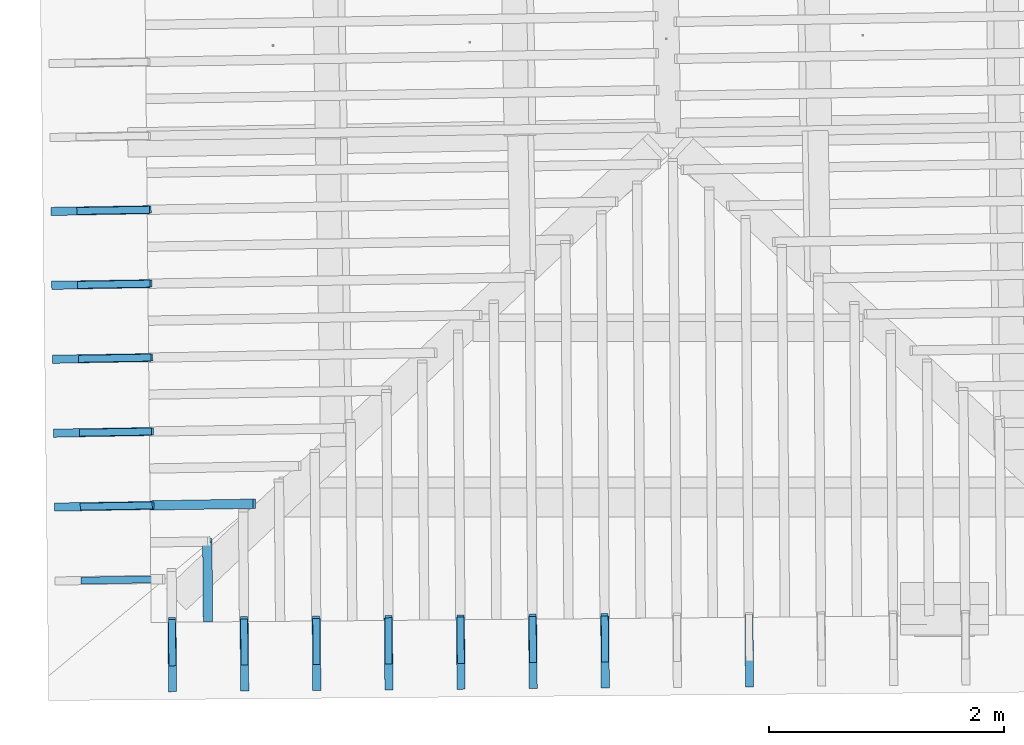
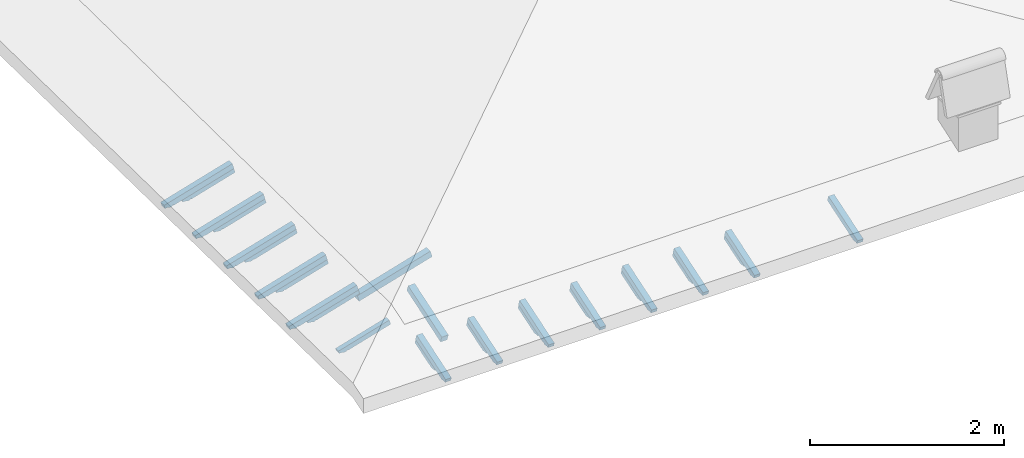
# One storey, part 9 of 19: 28 beams, 6 elements without a shape of their own.
"""IFC4 building model written with IfcOpenShell, lengths in metres."""

from ifc_helpers import new_model, entity, si_unit, converted_unit, derived_unit, direction, frame, origin, place, context, subcontext, project, spatial, line, arc, indexed_curve, outline, extrude, source, transform, mapped, material, type_object, type_shapes, element, aggregate, save


model = new_model("IFC4")

# Units and contexts
model_context = context("Model", 3, precision=1e-05, world=origin(), true_north=direction((6.123233995736766e-17, 1.0)))
body_context = subcontext(model_context, "Body", "Model", "MODEL_VIEW")
ifc_project = project(units=[si_unit("LENGTHUNIT", "METRE"), si_unit("AREAUNIT", "SQUARE_METRE"), si_unit("VOLUMEUNIT", "CUBIC_METRE"), converted_unit("PLANEANGLEUNIT", "DEGREE", entity("IfcPlaneAngleMeasure", 0.017453292519943278), si_unit("PLANEANGLEUNIT", "RADIAN"), dimensions=[0, 0, 0, 0, 0, 0, 0]), derived_unit("THERMALTRANSMITTANCEUNIT", [(si_unit("MASSUNIT", "GRAM", prefix="KILO"), 1), (si_unit("THERMODYNAMICTEMPERATUREUNIT", "KELVIN"), -1), (si_unit("TIMEUNIT", "SECOND"), -3)])], contexts=[model_context])

# Site, building, storey
site_placement = place(None, origin())
site = spatial("IfcSite", under=ifc_project, at=site_placement, CompositionType="ELEMENT")
building_placement = place(site_placement, origin())
building = spatial("IfcBuilding", under=site, at=building_placement, CompositionType="ELEMENT")
storey_placement = place(building_placement, frame((0.0, 0.0, 3.28)))
storey = spatial("IfcBuildingStorey", under=building, at=storey_placement, Name="Livello Copertura", CompositionType="ELEMENT", Elevation=3.28)

# Assembly, beam
assembly_1_placement = place(storey_placement, origin())
assembly_1 = element("IfcElementAssembly", 1, at=assembly_1_placement, inside=storey, Name="Sistema di travi strutturali:Sistema di travi strutturali", ObjectType="Sistema di travi strutturali:Sistema di travi strutturali", AssemblyPlace="NOTDEFINED", PredefinedType="BEAM_GRID")
ifc_material = material(Name="Legno - Legno da costruzione", Category="Legno")
beam_type_1 = type_object("IfcBeamType", Name="Legno:80x80", PredefinedType="JOIST", material=ifc_material)
shared_shape_1 = source(origin(), body_context, "Body", "SweptSolid", [
    extrude(outline(indexed_curve([(-0.4555, -0.04000000000000169), (0.4555, -0.04000000000000169), (0.4555, 0.04000000000000169), (-0.4555, 0.04000000000000169), (-0.4555, -0.04000000000000169)], self_intersect=False)), frame((0.0, 0.0, -0.040000000000005476), z_axis=(0.0, 0.0, 1.0), x_axis=(-1.0, 0.0, 0.0)), (0.0, 0.0, 1.0), 0.07999999999999997),
])
type_shapes(beam_type_1, [shared_shape_1])
beam_1_placement = place(assembly_1_placement, frame((-4.073064353074369, -2.2164447083472925, 0.20185039482082812), z_axis=(-0.2688805697492536, -0.0045944674406682776, 0.9631625667976582), x_axis=(0.9630219859926786, 0.01645553326302694, 0.26891982061526554)))
beam_1 = element("IfcBeam", 2, at=beam_1_placement, type_object=beam_type_1, material=ifc_material, Name="Legno:80x80", ObjectType="Legno:80x80", PredefinedType="JOIST", context=body_context, shape_type="MappedRepresentation", body=[
    mapped(shared_shape_1, transform((0.0, 0.0, 0.0), scale=1.0)),
])
aggregate(assembly_1, [beam_1])

assembly_2_placement = place(storey_placement, origin())
assembly_2 = element("IfcElementAssembly", 3, at=assembly_2_placement, inside=storey, Name="Sistema di travi strutturali:Sistema di travi strutturali", ObjectType="Sistema di travi strutturali:Sistema di travi strutturali", AssemblyPlace="NOTDEFINED", PredefinedType="BEAM_GRID")
beam_type_2 = type_object("IfcBeamType", Name="Legno:80x80", PredefinedType="JOIST", material=ifc_material)
shared_shape_2 = source(origin(), body_context, "Body", "SweptSolid", [
    extrude(outline(indexed_curve([(-0.3615, -0.04000000000000169), (0.3615, -0.04000000000000169), (0.3615, 0.04000000000000169), (-0.3615, 0.04000000000000169), (-0.3615, -0.04000000000000169)], self_intersect=False)), frame((0.0, 0.0, -0.040000000000005476), z_axis=(0.0, 0.0, 1.0), x_axis=(-1.0, 0.0, 0.0)), (0.0, 0.0, 1.0), 0.07999999999999997),
])
type_shapes(beam_type_2, [shared_shape_2])
beam_2_placement = place(assembly_2_placement, frame((-4.0317916790982125, -2.862327603977244, 0.09713162850545398), z_axis=(0.0033933227624359883, -0.32555047006150856, 0.9455185755993167), x_axis=(-0.007932350194779855, 0.9454855083215804, 0.3255675527049189)))
beam_2 = element("IfcBeam", 4, at=beam_2_placement, type_object=beam_type_2, material=ifc_material, Name="Legno:80x80", ObjectType="Legno:80x80", PredefinedType="JOIST", context=body_context, shape_type="MappedRepresentation", body=[
    mapped(shared_shape_2, transform((0.0, 0.0, 0.0), scale=1.0)),
])
aggregate(assembly_2, [beam_2])

# Assembly, beams
assembly_3_placement = place(storey_placement, origin())
assembly_3 = element("IfcElementAssembly", 5, at=assembly_3_placement, inside=storey, Name="Sistema di travi strutturali:Sistema di travi strutturali", ObjectType="Sistema di travi strutturali:Sistema di travi strutturali", AssemblyPlace="NOTDEFINED", PredefinedType="BEAM_GRID")
beam_type_3 = type_object("IfcBeamType", Name="70x70:70x70", PredefinedType="JOIST", material=ifc_material)
shared_shape_3 = source(origin(), body_context, "Body", "SweptSolid", [
    extrude(outline(indexed_curve([(-0.043571428571431446, -0.5697142857142851), (0.02642857142856851, -0.5697142857142851), (0.02642857142856851, 0.17828571428571474), (0.012428571428584384, 0.17828571428571122), (0.026181867029378903, 0.20199531881361585), (0.01842857142857067, 0.22828571428571487), (0.006014118110847633, 0.2512812898006978), (0.0034285714285708425, 0.2772857142857147), (-0.043571428571431446, 0.2772857142857147)], segments=[line(1, 2, 3, 4), arc(4, 5, 6), arc(6, 7, 8), line(8, 9, 1)], self_intersect=False)), frame((-0.1112142857142851, -0.03500000000000078, -0.00857142857143322), z_axis=(0.0, 1.0, 0.0), x_axis=(0.0, 0.0, -1.0)), (0.0, 0.0, 1.0), 0.06999999999999999),
])
type_shapes(beam_type_3, [shared_shape_3])
beam_3_placement = place(assembly_3_placement, frame((-4.954810229137485, -2.23151144493706, 0.09269859893071386), z_axis=(-0.2688805697492528, -0.004594467440668774, 0.9631625667976585), x_axis=(0.9630219859926787, 0.016455533263033215, 0.2689198206152647)))
beam_3 = element("IfcBeam", 6, at=beam_3_placement, type_object=beam_type_3, material=ifc_material, Name="70x70:70x70", ObjectType="70x70:70x70", PredefinedType="JOIST", context=body_context, shape_type="MappedRepresentation", body=[
    mapped(shared_shape_3, transform((0.0, 0.0, 0.0), scale=1.0)),
])
beam_type_4 = type_object("IfcBeamType", Name="70x70:70x70", PredefinedType="JOIST", material=ifc_material)
shared_shape_4 = source(origin(), body_context, "Body", "SweptSolid", [
    extrude(outline(indexed_curve([(-0.04357142857143148, -0.5704285714285708), (0.02642857142856849, -0.5704285714285708), (0.02642857142856849, 0.17857142857142902), (0.01242857142858438, 0.17857142857142563), (0.0261818670293789, 0.20228103309933027), (0.018428571428570715, 0.22857142857142917), (0.006014118110847679, 0.2515670040864121), (0.00342857142857088, 0.27757142857142897), (-0.04357142857143148, 0.27757142857142897)], segments=[line(1, 2, 3, 4), arc(4, 5, 6), arc(6, 7, 8), line(8, 9, 1)], self_intersect=False)), frame((-0.11142857142857084, -0.03500000000000078, -0.008571428571433224), z_axis=(0.0, 1.0, 0.0), x_axis=(0.0, 0.0, -1.0)), (0.0, 0.0, 1.0), 0.06999999999999999),
])
type_shapes(beam_type_4, [shared_shape_4])
beam_4_placement = place(assembly_3_placement, frame((-4.9615916042821295, -1.6015353542947481, 0.09381058631602324), z_axis=(-0.26888056974925356, -0.004594467440668793, 0.9631625667976582), x_axis=(0.9630219859926785, 0.01645553326303299, 0.26891982061526554)))
beam_4 = element("IfcBeam", 7, at=beam_4_placement, type_object=beam_type_4, material=ifc_material, Name="70x70:70x70", ObjectType="70x70:70x70", PredefinedType="JOIST", context=body_context, shape_type="MappedRepresentation", body=[
    mapped(shared_shape_4, transform((0.0, 0.0, 0.0), scale=1.0)),
])
beam_type_5 = type_object("IfcBeamType", Name="70x70:70x70", PredefinedType="JOIST", material=ifc_material)
shared_shape_5 = source(origin(), body_context, "Body", "SweptSolid", [
    extrude(outline(indexed_curve([(-0.043571428571431495, -0.5718571428571425), (0.026428571428568505, -0.5718571428571425), (0.026428571428568505, 0.17914285714285763), (0.012428571428584407, 0.17914285714285424), (0.026181867029378924, 0.20285246167075888), (0.018428571428570704, 0.2291428571428578), (0.006014118110847667, 0.2521384326578407), (0.0034285714285708724, 0.2781428571428576), (-0.043571428571431495, 0.2781428571428576)], segments=[line(1, 2, 3, 4), arc(4, 5, 6), arc(6, 7, 8), line(8, 9, 1)], self_intersect=False)), frame((-0.11185714285714239, -0.03500000000000078, -0.00857142857143322), z_axis=(0.0, 1.0, 0.0), x_axis=(0.0, 0.0, -1.0)), (0.0, 0.0, 1.0), 0.06999999999999999),
])
type_shapes(beam_type_5, [shared_shape_5])
beam_5_placement = place(assembly_3_placement, frame((-4.968372979426771, -0.9715592636524365, 0.09492257370133195), z_axis=(-0.26888056974925356, -0.004594467440668792, 0.9631625667976582), x_axis=(0.9630219859926785, 0.01645553326303318, 0.26891982061526554)))
beam_5 = element("IfcBeam", 8, at=beam_5_placement, type_object=beam_type_5, material=ifc_material, Name="70x70:70x70", ObjectType="70x70:70x70", PredefinedType="JOIST", context=body_context, shape_type="MappedRepresentation", body=[
    mapped(shared_shape_5, transform((0.0, 0.0, 0.0), scale=1.0)),
])
beam_type_6 = type_object("IfcBeamType", Name="70x70:70x70", PredefinedType="JOIST", material=ifc_material)
shared_shape_6 = source(origin(), body_context, "Body", "SweptSolid", [
    extrude(outline(indexed_curve([(-0.043571428571431474, -0.5725714285714281), (0.026428571428568505, -0.5725714285714281), (0.026428571428568505, 0.17942857142857194), (0.012428571428584384, 0.17942857142856855), (0.026181867029378903, 0.20313817595647318), (0.01842857142857069, 0.22942857142857206), (0.0060141181108476546, 0.252424146943555), (0.0034285714285708555, 0.2784285714285719), (-0.043571428571431474, 0.2784285714285719)], segments=[line(1, 2, 3, 4), arc(4, 5, 6), arc(6, 7, 8), line(8, 9, 1)], self_intersect=False)), frame((-0.11207142857142802, -0.03500000000000078, -0.008571428571433214), z_axis=(0.0, 1.0, 0.0), x_axis=(0.0, 0.0, -1.0)), (0.0, 0.0, 1.0), 0.06999999999999999),
])
type_shapes(beam_type_6, [shared_shape_6])
beam_6_placement = place(assembly_3_placement, frame((-4.975154354571416, -0.34158317301012453, 0.09603456108664044), z_axis=(-0.2688805697492534, -0.004594467440668787, 0.9631625667976583), x_axis=(0.9630219859926785, 0.01645553326303317, 0.2689198206152653)))
beam_6 = element("IfcBeam", 9, at=beam_6_placement, type_object=beam_type_6, material=ifc_material, Name="70x70:70x70", ObjectType="70x70:70x70", PredefinedType="JOIST", context=body_context, shape_type="MappedRepresentation", body=[
    mapped(shared_shape_6, transform((0.0, 0.0, 0.0), scale=1.0)),
])
beam_type_7 = type_object("IfcBeamType", Name="70x70:70x70", PredefinedType="JOIST", material=ifc_material)
shared_shape_7 = source(origin(), body_context, "Body", "SweptSolid", [
    extrude(outline(indexed_curve([(-0.04357142857143152, -0.573285714285714), (0.026428571428568467, -0.573285714285714), (0.026428571428568467, 0.17971428571428624), (0.012428571428584369, 0.17971428571428286), (0.026181867029378886, 0.2034238902421875), (0.018428571428570784, 0.2297142857142864), (0.006014118110847748, 0.2527098612292693), (0.003428571428570954, 0.2787142857142862), (-0.04357142857143152, 0.2787142857142862)], segments=[line(1, 2, 3, 4), arc(4, 5, 6), arc(6, 7, 8), line(8, 9, 1)], self_intersect=False)), frame((-0.11228571428571384, -0.03500000000000078, -0.008571428571433256), z_axis=(0.0, 1.0, 0.0), x_axis=(0.0, 0.0, -1.0)), (0.0, 0.0, 1.0), 0.06999999999999999),
])
type_shapes(beam_type_7, [shared_shape_7])
beam_7_placement = place(assembly_3_placement, frame((-4.981935729716061, 0.2883929176321871, 0.09714654847194915), z_axis=(-0.2688805697492537, -0.004594467440668792, 0.9631625667976582), x_axis=(0.9630219859926785, 0.016455533263033152, 0.26891982061526565)))
beam_7 = element("IfcBeam", 10, at=beam_7_placement, type_object=beam_type_7, material=ifc_material, Name="70x70:70x70", ObjectType="70x70:70x70", PredefinedType="JOIST", context=body_context, shape_type="MappedRepresentation", body=[
    mapped(shared_shape_7, transform((0.0, 0.0, 0.0), scale=1.0)),
])
aggregate(assembly_3, [beam_3, beam_4, beam_5, beam_6, beam_7])

assembly_4_placement = place(storey_placement, origin())
assembly_4 = element("IfcElementAssembly", 11, at=assembly_4_placement, inside=storey, Name="Sistema di travi strutturali:Sistema di travi strutturali", ObjectType="Sistema di travi strutturali:Sistema di travi strutturali", AssemblyPlace="NOTDEFINED", PredefinedType="BEAM_GRID")
beam_type_8 = type_object("IfcBeamType", Name="60x60:60x60", PredefinedType="JOIST", material=ifc_material)
shared_shape_8 = source(origin(), body_context, "Body", "SweptSolid", [
    extrude(outline(indexed_curve([(-0.03585714285711795, -0.41771428571428604), (0.024142857142882033, -0.41771428571428604), (0.024142857142882033, 0.11928571428571419), (0.007142857142882096, 0.11928571428571419), (0.022800314198399032, 0.1368821303412819), (0.020142857142794478, 0.16028571428571534), (0.006097362558745679, 0.18843930273369514), (-0.003857142857204738, 0.21828571428571414), (-0.03585714285711795, 0.2182857142857142)], segments=[line(1, 2, 3, 4), arc(4, 5, 6), arc(6, 7, 8), line(8, 9, 1)], self_intersect=False)), frame((0.04028571428571415, -0.030000000000000786, -0.005857142857119684), z_axis=(0.0, 1.0, 0.0), x_axis=(0.0, 0.0, -1.0)), (0.0, 0.0, 1.0), 0.059999999999999984),
])
type_shapes(beam_type_8, [shared_shape_8])
beam_8_placement = place(assembly_4_placement, frame((-4.930551616959139, -2.861188895195729, 0.028981044703557224), z_axis=(-0.26888056974925273, -0.004594467440668775, 0.9631625667976585), x_axis=(0.9630219859926787, 0.016455533263032885, 0.26891982061526465)))
beam_8 = element("IfcBeam", 12, at=beam_8_placement, type_object=beam_type_8, material=ifc_material, Name="60x60:60x60", ObjectType="60x60:60x60", PredefinedType="JOIST", context=body_context, shape_type="MappedRepresentation", body=[
    mapped(shared_shape_8, transform((0.0, 0.0, 0.0), scale=1.0)),
])
beam_type_9 = type_object("IfcBeamType", Name="60x60:60x60", PredefinedType="JOIST", material=ifc_material)
shared_shape_9 = source(origin(), body_context, "Body", "SweptSolid", [
    extrude(outline(indexed_curve([(-0.03585714285711782, -0.4184285714285716), (0.024142857142882158, -0.4184285714285716), (0.024142857142882158, 0.11957142857142841), (0.0071428571428822215, 0.11957142857142841), (0.022800314198399153, 0.13716784462699613), (0.020142857142794162, 0.16057142857142956), (0.0060973625587453645, 0.18872501701940936), (-0.003857142857205052, 0.21857142857142836), (-0.03585714285711782, 0.21857142857142842)], segments=[line(1, 2, 3, 4), arc(4, 5, 6), arc(6, 7, 8), line(8, 9, 1)], self_intersect=False)), frame((0.04007142857142848, -0.030000000000000786, -0.0058571428571195586), z_axis=(0.0, 1.0, 0.0), x_axis=(0.0, 0.0, -1.0)), (0.0, 0.0, 1.0), 0.059999999999999984),
])
type_shapes(beam_type_9, [shared_shape_9])
beam_9_placement = place(assembly_4_placement, frame((-4.937332992103783, -2.231212804553417, 0.030093032088865712), z_axis=(-0.2688805697492528, -0.004594467440668774, 0.9631625667976585), x_axis=(0.9630219859926787, 0.016455533263033215, 0.2689198206152647)))
beam_9 = element("IfcBeam", 13, at=beam_9_placement, type_object=beam_type_9, material=ifc_material, Name="60x60:60x60", ObjectType="60x60:60x60", PredefinedType="JOIST", context=body_context, shape_type="MappedRepresentation", body=[
    mapped(shared_shape_9, transform((0.0, 0.0, 0.0), scale=1.0)),
])
beam_type_10 = type_object("IfcBeamType", Name="60x60:60x60", PredefinedType="JOIST", material=ifc_material)
shared_shape_10 = source(origin(), body_context, "Body", "SweptSolid", [
    extrude(outline(indexed_curve([(-0.03585714285711707, -0.4191428571428573), (0.02414285714288291, -0.4191428571428573), (0.02414285714288291, 0.11985714285714275), (0.0071428571428830715, 0.11985714285714277), (0.022800314198400007, 0.1374535589127105), (0.02014285714279224, 0.16085714285714373), (0.006097362558743442, 0.1890107313051235), (-0.0038571428572069747, 0.21885714285714256), (-0.03585714285711707, 0.21885714285714278)], segments=[line(1, 2, 3, 4), arc(4, 5, 6), arc(6, 7, 8), line(8, 9, 1)], self_intersect=False)), frame((0.03985714285714266, -0.030000000000000786, -0.005857142857118807), z_axis=(0.0, 1.0, 0.0), x_axis=(0.0, 0.0, -1.0)), (0.0, 0.0, 1.0), 0.059999999999999984),
])
type_shapes(beam_type_10, [shared_shape_10])
beam_10_placement = place(assembly_4_placement, frame((-4.944114367248429, -1.6012367139111046, 0.031205019474175533), z_axis=(-0.26888056974925356, -0.004594467440668793, 0.9631625667976582), x_axis=(0.9630219859926785, 0.01645553326303299, 0.26891982061526554)))
beam_10 = element("IfcBeam", 14, at=beam_10_placement, type_object=beam_type_10, material=ifc_material, Name="60x60:60x60", ObjectType="60x60:60x60", PredefinedType="JOIST", context=body_context, shape_type="MappedRepresentation", body=[
    mapped(shared_shape_10, transform((0.0, 0.0, 0.0), scale=1.0)),
])
beam_type_11 = type_object("IfcBeamType", Name="60x60:60x60", PredefinedType="JOIST", material=ifc_material)
shared_shape_11 = source(origin(), body_context, "Body", "SweptSolid", [
    extrude(outline(indexed_curve([(-0.03585714285711793, -0.4205714285714288), (0.02414285714288205, -0.4205714285714288), (0.02414285714288205, 0.12042857142857129), (0.007142857142882115, 0.12042857142857129), (0.022800314198399046, 0.13802498748413905), (0.02014285714279443, 0.16142857142857242), (0.00609736255874563, 0.18958215987655222), (-0.003857142857204787, 0.21942857142857125), (-0.03585714285711793, 0.21942857142857133)], segments=[line(1, 2, 3, 4), arc(4, 5, 6), arc(6, 7, 8), line(8, 9, 1)], self_intersect=False)), frame((0.039428571428571306, -0.030000000000000786, -0.005857142857119665), z_axis=(0.0, 1.0, 0.0), x_axis=(0.0, 0.0, -1.0)), (0.0, 0.0, 1.0), 0.059999999999999984),
])
type_shapes(beam_type_11, [shared_shape_11])
beam_11_placement = place(assembly_4_placement, frame((-4.9508957423930715, -0.9712606232687931, 0.032317006859483355), z_axis=(-0.26888056974925356, -0.004594467440668792, 0.9631625667976582), x_axis=(0.9630219859926785, 0.01645553326303318, 0.26891982061526554)))
beam_11 = element("IfcBeam", 15, at=beam_11_placement, type_object=beam_type_11, material=ifc_material, Name="60x60:60x60", ObjectType="60x60:60x60", PredefinedType="JOIST", context=body_context, shape_type="MappedRepresentation", body=[
    mapped(shared_shape_11, transform((0.0, 0.0, 0.0), scale=1.0)),
])
beam_type_12 = type_object("IfcBeamType", Name="60x60:60x60", PredefinedType="JOIST", material=ifc_material)
shared_shape_12 = source(origin(), body_context, "Body", "SweptSolid", [
    extrude(outline(indexed_curve([(-0.035857142857118024, -0.42128571428571454), (0.024142857142881953, -0.42128571428571454), (0.024142857142881953, 0.12071428571428562), (0.007142857142882019, 0.12071428571428562), (0.02280031419839895, 0.13831070176985333), (0.02014285714279467, 0.16171428571428675), (0.006097362558745873, 0.18986787416226653), (-0.0038571428572045444, 0.21971428571428558), (-0.035857142857118024, 0.21971428571428564)], segments=[line(1, 2, 3, 4), arc(4, 5, 6), arc(6, 7, 8), line(8, 9, 1)], self_intersect=False)), frame((0.03921428571428559, -0.030000000000000786, -0.0058571428571197615), z_axis=(0.0, 1.0, 0.0), x_axis=(0.0, 0.0, -1.0)), (0.0, 0.0, 1.0), 0.059999999999999984),
])
type_shapes(beam_type_12, [shared_shape_12])
beam_12_placement = place(assembly_4_placement, frame((-4.957677117537715, -0.3412845326264811, 0.033428994244792065), z_axis=(-0.2688805697492534, -0.004594467440668787, 0.9631625667976583), x_axis=(0.9630219859926785, 0.01645553326303317, 0.2689198206152653)))
beam_12 = element("IfcBeam", 16, at=beam_12_placement, type_object=beam_type_12, material=ifc_material, Name="60x60:60x60", ObjectType="60x60:60x60", PredefinedType="JOIST", context=body_context, shape_type="MappedRepresentation", body=[
    mapped(shared_shape_12, transform((0.0, 0.0, 0.0), scale=1.0)),
])
beam_type_13 = type_object("IfcBeamType", Name="60x60:60x60", PredefinedType="JOIST", material=ifc_material)
shared_shape_13 = source(origin(), body_context, "Body", "SweptSolid", [
    extrude(outline(indexed_curve([(-0.035857142857117746, -0.4220000000000003), (0.024142857142882237, -0.4220000000000003), (0.024142857142882237, 0.1209999999999999), (0.007142857142882299, 0.1209999999999999), (0.022800314198399233, 0.13859641605556763), (0.02014285714279397, 0.16200000000000103), (0.006097362558745171, 0.19015358844798083), (-0.0038571428572052456, 0.21999999999999986), (-0.035857142857117746, 0.21999999999999995)], segments=[line(1, 2, 3, 4), arc(4, 5, 6), arc(6, 7, 8), line(8, 9, 1)], self_intersect=False)), frame((0.03899999999999987, -0.030000000000000786, -0.005857142857119481), z_axis=(0.0, 1.0, 0.0), x_axis=(0.0, 0.0, -1.0)), (0.0, 0.0, 1.0), 0.059999999999999984),
])
type_shapes(beam_type_13, [shared_shape_13])
beam_13_placement = place(assembly_4_placement, frame((-4.964458492682359, 0.28869155801583063, 0.034540981630101), z_axis=(-0.2688805697492537, -0.004594467440668792, 0.9631625667976582), x_axis=(0.9630219859926785, 0.016455533263033152, 0.26891982061526565)))
beam_13 = element("IfcBeam", 17, at=beam_13_placement, type_object=beam_type_13, material=ifc_material, Name="60x60:60x60", ObjectType="60x60:60x60", PredefinedType="JOIST", context=body_context, shape_type="MappedRepresentation", body=[
    mapped(shared_shape_13, transform((0.0, 0.0, 0.0), scale=1.0)),
])
aggregate(assembly_4, [beam_8, beam_9, beam_10, beam_11, beam_12, beam_13])

assembly_5_placement = place(storey_placement, origin())
assembly_5 = element("IfcElementAssembly", 18, at=assembly_5_placement, inside=storey, Name="Sistema di travi strutturali:Sistema di travi strutturali", ObjectType="Sistema di travi strutturali:Sistema di travi strutturali", AssemblyPlace="NOTDEFINED", PredefinedType="BEAM_GRID")
beam_type_14 = type_object("IfcBeamType", Name="70x70:70x70", PredefinedType="JOIST", material=ifc_material)
shared_shape_14 = source(origin(), body_context, "Body", "SweptSolid", [
    extrude(outline(indexed_curve([(-0.043571428571431474, -0.4118571428571424), (0.026428571428568512, -0.4118571428571424), (0.026428571428568512, 0.1151428571428576), (0.012428571428584416, 0.11514285714285424), (0.02618186702937893, 0.13885246167075888), (0.018428571428570677, 0.16514285714285784), (0.006014118110847642, 0.1881384326578407), (0.003428571428570848, 0.21414285714285763), (-0.043571428571431474, 0.21414285714285763)], segments=[line(1, 2, 3, 4), arc(4, 5, 6), arc(6, 7, 8), line(8, 9, 1)], self_intersect=False)), frame((-0.06385714285714238, -0.03500000000000078, -0.008571428571433209), z_axis=(0.0, 1.0, 0.0), x_axis=(0.0, 0.0, -1.0)), (0.0, 0.0, 1.0), 0.06999999999999999),
])
type_shapes(beam_type_14, [shared_shape_14])
beam_14_placement = place(assembly_5_placement, frame((0.5838736108558032, -3.495013301323861, 0.0023727703570213254), z_axis=(0.0033933227624359913, -0.32555047006150895, 0.9455185755993166), x_axis=(-0.007932350194779591, 0.9454855083215802, 0.3255675527049193)))
beam_14 = element("IfcBeam", 19, at=beam_14_placement, type_object=beam_type_14, material=ifc_material, Name="70x70:70x70", ObjectType="70x70:70x70", PredefinedType="JOIST", context=body_context, shape_type="MappedRepresentation", body=[
    mapped(shared_shape_14, transform((0.0, 0.0, 0.0), scale=1.0)),
])
beam_15_placement = place(assembly_5_placement, frame((-0.6452809147108073, -3.5055576814267644, 0.003153495506372561), z_axis=(0.003393322762435987, -0.3255504700615084, 0.9455185755993168), x_axis=(-0.007932350194779503, 0.9454855083215804, 0.3255675527049188)))
beam_15 = element("IfcBeam", 20, at=beam_15_placement, type_object=beam_type_14, material=ifc_material, Name="70x70:70x70", ObjectType="70x70:70x70", PredefinedType="JOIST", context=body_context, shape_type="MappedRepresentation", body=[
    mapped(shared_shape_14, transform((0.0, 0.0, 0.0), scale=1.0)),
])
beam_16_placement = place(assembly_5_placement, frame((-1.2598581774941124, -3.5108298714782156, 0.003543858081048512), z_axis=(0.003393322762435991, -0.3255504700615088, 0.9455185755993167), x_axis=(-0.007932350194779553, 0.9454855083215803, 0.32556755270491916)))
beam_16 = element("IfcBeam", 21, at=beam_16_placement, type_object=beam_type_14, material=ifc_material, Name="70x70:70x70", ObjectType="70x70:70x70", PredefinedType="JOIST", context=body_context, shape_type="MappedRepresentation", body=[
    mapped(shared_shape_14, transform((0.0, 0.0, 0.0), scale=1.0)),
])
beam_17_placement = place(assembly_5_placement, frame((-1.874435440277417, -3.516102061529668, 0.003934220655723575), z_axis=(0.003393322762435987, -0.3255504700615084, 0.9455185755993168), x_axis=(-0.007932350194779619, 0.9454855083215806, 0.3255675527049187)))
beam_17 = element("IfcBeam", 22, at=beam_17_placement, type_object=beam_type_14, material=ifc_material, Name="70x70:70x70", ObjectType="70x70:70x70", PredefinedType="JOIST", context=body_context, shape_type="MappedRepresentation", body=[
    mapped(shared_shape_14, transform((0.0, 0.0, 0.0), scale=1.0)),
])
beam_18_placement = place(assembly_5_placement, frame((-2.489012703060723, -3.5213742515811193, 0.004324583230399526), z_axis=(0.0033933227624359844, -0.32555047006150806, 0.945518575599317), x_axis=(-0.00793235019478006, 0.9454855083215806, 0.3255675527049184)))
beam_18 = element("IfcBeam", 23, at=beam_18_placement, type_object=beam_type_14, material=ifc_material, Name="70x70:70x70", ObjectType="70x70:70x70", PredefinedType="JOIST", context=body_context, shape_type="MappedRepresentation", body=[
    mapped(shared_shape_14, transform((0.0, 0.0, 0.0), scale=1.0)),
])
beam_19_placement = place(assembly_5_placement, frame((-3.1035899658440274, -3.5266464416325696, 0.0047149458050748105), z_axis=(0.00339332276243599, -0.3255504700615087, 0.9455185755993167), x_axis=(-0.007932350194779728, 0.9454855083215803, 0.3255675527049191)))
beam_19 = element("IfcBeam", 24, at=beam_19_placement, type_object=beam_type_14, material=ifc_material, Name="70x70:70x70", ObjectType="70x70:70x70", PredefinedType="JOIST", context=body_context, shape_type="MappedRepresentation", body=[
    mapped(shared_shape_14, transform((0.0, 0.0, 0.0), scale=1.0)),
])
beam_20_placement = place(assembly_5_placement, frame((-3.718167228627333, -3.5319186316840216, 0.005105308379750539), z_axis=(0.0033933227624359952, -0.3255504700615094, 0.9455185755993165), x_axis=(-0.007932350194779395, 0.9454855083215801, 0.32556755270491977)))
beam_20 = element("IfcBeam", 25, at=beam_20_placement, type_object=beam_type_14, material=ifc_material, Name="70x70:70x70", ObjectType="70x70:70x70", PredefinedType="JOIST", context=body_context, shape_type="MappedRepresentation", body=[
    mapped(shared_shape_14, transform((0.0, 0.0, 0.0), scale=1.0)),
])
beam_21_placement = place(assembly_5_placement, frame((-4.332744491410638, -3.5371908217354737, 0.005495670954425824), z_axis=(0.0033933227624359874, -0.3255504700615084, 0.9455185755993168), x_axis=(-0.007932350194779838, 0.9454855083215804, 0.3255675527049188)))
beam_21 = element("IfcBeam", 26, at=beam_21_placement, type_object=beam_type_14, material=ifc_material, Name="70x70:70x70", ObjectType="70x70:70x70", PredefinedType="JOIST", context=body_context, shape_type="MappedRepresentation", body=[
    mapped(shared_shape_14, transform((0.0, 0.0, 0.0), scale=1.0)),
])
aggregate(assembly_5, [beam_14, beam_15, beam_16, beam_17, beam_18, beam_19, beam_20, beam_21])

assembly_6_placement = place(storey_placement, origin())
assembly_6 = element("IfcElementAssembly", 27, at=assembly_6_placement, inside=storey, Name="Sistema di travi strutturali:Sistema di travi strutturali", ObjectType="Sistema di travi strutturali:Sistema di travi strutturali", AssemblyPlace="NOTDEFINED", PredefinedType="BEAM_GRID")
beam_type_15 = type_object("IfcBeamType", Name="60x60:60x60", PredefinedType="JOIST", material=ifc_material)
shared_shape_15 = source(origin(), body_context, "Body", "SweptSolid", [
    extrude(outline(indexed_curve([(-0.035857142857118045, -0.26057142857142884), (0.024142857142881936, -0.26057142857142884), (0.024142857142881936, 0.05642857142857127), (0.0071428571428819995, 0.05642857142857127), (0.022800314198398935, 0.07402498748413901), (0.02014285714279472, 0.0974285714285724), (0.006097362558745921, 0.1255821598765522), (-0.003857142857204496, 0.15542857142857122), (-0.035857142857118045, 0.15542857142857128)], segments=[line(1, 2, 3, 4), arc(4, 5, 6), arc(6, 7, 8), line(8, 9, 1)], self_intersect=False)), frame((0.08742857142857127, -0.030000000000000786, -0.005857142857119781), z_axis=(0.0, 1.0, 0.0), x_axis=(0.0, 0.0, -1.0)), (0.0, 0.0, 1.0), 0.059999999999999984),
])
type_shapes(beam_type_15, [shared_shape_15])
beam_22_placement = place(assembly_6_placement, frame((-0.6455014806903654, -3.4843969008727664, -0.05830521190758309), z_axis=(0.0033933227624359887, -0.3255504700615084, 0.9455185755993168), x_axis=(-0.007932350194779503, 0.9454855083215804, 0.3255675527049188)))
beam_22 = element("IfcBeam", 28, at=beam_22_placement, type_object=beam_type_15, material=ifc_material, Name="60x60:60x60", ObjectType="60x60:60x60", PredefinedType="JOIST", context=body_context, shape_type="MappedRepresentation", body=[
    mapped(shared_shape_15, transform((0.0, 0.0, 0.0), scale=1.0)),
])
beam_23_placement = place(assembly_6_placement, frame((-1.2600787434736707, -3.489669090924218, -0.05791484933290669), z_axis=(0.003393322762435992, -0.32555047006150883, 0.9455185755993166), x_axis=(-0.007932350194779553, 0.9454855083215803, 0.32556755270491916)))
beam_23 = element("IfcBeam", 29, at=beam_23_placement, type_object=beam_type_15, material=ifc_material, Name="60x60:60x60", ObjectType="60x60:60x60", PredefinedType="JOIST", context=body_context, shape_type="MappedRepresentation", body=[
    mapped(shared_shape_15, transform((0.0, 0.0, 0.0), scale=1.0)),
])
beam_24_placement = place(assembly_6_placement, frame((-1.8746560062569755, -3.49494128097567, -0.05752448675823141), z_axis=(0.0033933227624359887, -0.3255504700615084, 0.9455185755993168), x_axis=(-0.007932350194779619, 0.9454855083215806, 0.3255675527049187)))
beam_24 = element("IfcBeam", 30, at=beam_24_placement, type_object=beam_type_15, material=ifc_material, Name="60x60:60x60", ObjectType="60x60:60x60", PredefinedType="JOIST", context=body_context, shape_type="MappedRepresentation", body=[
    mapped(shared_shape_15, transform((0.0, 0.0, 0.0), scale=1.0)),
])
beam_25_placement = place(assembly_6_placement, frame((-2.489233269040281, -3.500213471027121, -0.057134124183556345), z_axis=(0.003393322762435986, -0.32555047006150806, 0.945518575599317), x_axis=(-0.00793235019478006, 0.9454855083215806, 0.3255675527049184)))
beam_25 = element("IfcBeam", 31, at=beam_25_placement, type_object=beam_type_15, material=ifc_material, Name="60x60:60x60", ObjectType="60x60:60x60", PredefinedType="JOIST", context=body_context, shape_type="MappedRepresentation", body=[
    mapped(shared_shape_15, transform((0.0, 0.0, 0.0), scale=1.0)),
])
beam_26_placement = place(assembly_6_placement, frame((-3.103810531823585, -3.5054856610785725, -0.056743761608880394), z_axis=(0.0033933227624359913, -0.3255504700615088, 0.9455185755993166), x_axis=(-0.007932350194779728, 0.9454855083215803, 0.3255675527049191)))
beam_26 = element("IfcBeam", 32, at=beam_26_placement, type_object=beam_type_15, material=ifc_material, Name="60x60:60x60", ObjectType="60x60:60x60", PredefinedType="JOIST", context=body_context, shape_type="MappedRepresentation", body=[
    mapped(shared_shape_15, transform((0.0, 0.0, 0.0), scale=1.0)),
])
beam_27_placement = place(assembly_6_placement, frame((-3.71838779460689, -3.510757851130024, -0.05635339903420533), z_axis=(0.003393322762435996, -0.32555047006150944, 0.9455185755993164), x_axis=(-0.007932350194779395, 0.9454855083215801, 0.32556755270491977)))
beam_27 = element("IfcBeam", 33, at=beam_27_placement, type_object=beam_type_15, material=ifc_material, Name="60x60:60x60", ObjectType="60x60:60x60", PredefinedType="JOIST", context=body_context, shape_type="MappedRepresentation", body=[
    mapped(shared_shape_15, transform((0.0, 0.0, 0.0), scale=1.0)),
])
beam_28_placement = place(assembly_6_placement, frame((-4.332965057390196, -3.516030041181476, -0.05596303645953027), z_axis=(0.003393322762435989, -0.3255504700615084, 0.9455185755993168), x_axis=(-0.007932350194779838, 0.9454855083215804, 0.3255675527049188)))
beam_28 = element("IfcBeam", 34, at=beam_28_placement, type_object=beam_type_15, material=ifc_material, Name="60x60:60x60", ObjectType="60x60:60x60", PredefinedType="JOIST", context=body_context, shape_type="MappedRepresentation", body=[
    mapped(shared_shape_15, transform((0.0, 0.0, 0.0), scale=1.0)),
])
aggregate(assembly_6, [beam_22, beam_23, beam_24, beam_25, beam_26, beam_27, beam_28])

save(model, "model.ifc")
